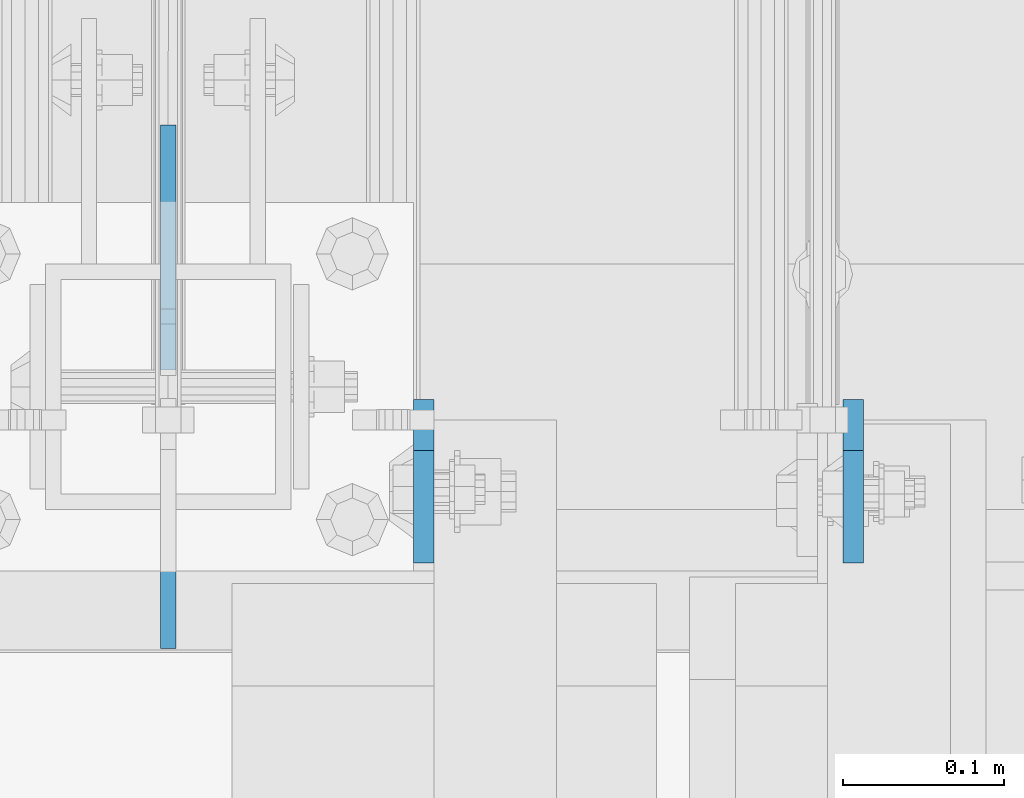
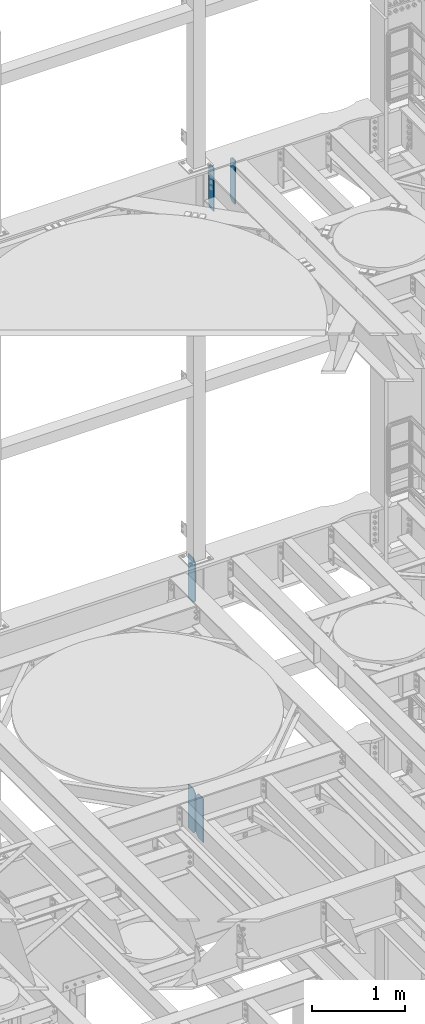
# One storey, part 1801 of 1876: 5 plates, 3 elements without a shape of their own.
"""IFC2X3 building model written with IfcOpenShell, lengths in millimetres."""

import ifcopenshell
import ifcopenshell.guid

model = None  # the IFC model being written
_history = None  # IfcOwnerHistory: only IFC2X3 demands one
_inside = {}  # id of a spatial element -> (the spatial element, [elements in it])
_under = {}  # id of a project, library or spatial element -> (it, [spatial elements below it])
_declared = {}  # id of a project -> (the project, [libraries it declares])
_typed = {}  # id of a type object -> (the type object, [elements of that type])
_made_of = {}  # id of a material, layer set ... -> (it, [elements and type objects made of it])


def new_model(schema):
    """Start an empty IFC model of exactly this schema.

    Asked for "IFC4X3", IfcOpenShell would pick the latest addendum, in which some entities
    have other attributes; the version numbers below select the first issue.
    IFC2X3 requires an IfcOwnerHistory on every rooted entity: one is made here for all.
    """
    global model, _history
    if schema == "IFC4X3":
        model = ifcopenshell.file(schema_version=(4, 3, 0, 0))
    else:
        model = ifcopenshell.file(schema=schema)
    _inside.clear()
    _under.clear()
    _declared.clear()
    _typed.clear()
    _made_of.clear()
    _history = None
    if model.schema == "IFC2X3":
        org = make("IfcOrganization", Name="unknown")
        user = make(
            "IfcPersonAndOrganization",
            ThePerson=make("IfcPerson", FamilyName="unknown"),
            TheOrganization=org,
        )
        app = make(
            "IfcApplication",
            ApplicationDeveloper=org,
            Version="unknown",
            ApplicationFullName="unknown",
            ApplicationIdentifier="unknown",
        )
        _history = make(
            "IfcOwnerHistory",
            OwningUser=user,
            OwningApplication=app,
            ChangeAction="ADDED",
            CreationDate=0,
        )
    return model


def make(cls, **values):
    """One entity of the class cls with the attributes given. An attribute that is None is left unset."""
    return model.create_entity(
        cls, **{name: value for name, value in values.items() if value is not None}
    )


def rooted(cls, **values):
    """An entity with a GlobalId (a new one), such as an element, a storey or a relation."""
    return make(cls, GlobalId=ifcopenshell.guid.new(), OwnerHistory=_history, **values)


def si_unit(unit_type, name, prefix=None):
    """IfcSIUnit, for example si_unit("LENGTHUNIT", "METRE", prefix="MILLI")."""
    return make("IfcSIUnit", UnitType=unit_type, Prefix=prefix, Name=name)


def assignment(units):
    """IfcUnitAssignment: the units of a project."""
    return None if units is None else make("IfcUnitAssignment", Units=units)


def point(xyz):
    """IfcCartesianPoint."""
    return None if xyz is None else make("IfcCartesianPoint", Coordinates=xyz)


def direction(xyz):
    """IfcDirection."""
    return None if xyz is None else make("IfcDirection", DirectionRatios=xyz)


def frame(location, z_axis=None, x_axis=None):
    """IfcAxis2Placement3D, a coordinate frame: its origin and axes. An axis left out is left unset."""
    return make(
        "IfcAxis2Placement3D",
        Location=point(location),
        Axis=direction(z_axis),
        RefDirection=direction(x_axis),
    )


def origin_with_axes():
    """The frame at (0, 0, 0) with the z axis (0, 0, 1) and the x axis (1, 0, 0) written out."""
    return frame((0.0, 0.0, 0.0), z_axis=(0.0, 0.0, 1.0), x_axis=(1.0, 0.0, 0.0))


def place(relative_to, where):
    """IfcLocalPlacement: puts the frame where relative to a parent placement (None: the world)."""
    return make(
        "IfcLocalPlacement", PlacementRelTo=relative_to, RelativePlacement=where
    )


def context(
    kind, dimensions, precision=None, world=None, true_north=None, identifier=None
):
    """IfcGeometricRepresentationContext, for example the 3D "Model" context."""
    return make(
        "IfcGeometricRepresentationContext",
        ContextIdentifier=identifier,
        ContextType=kind,
        CoordinateSpaceDimension=dimensions,
        Precision=precision,
        WorldCoordinateSystem=world,
        TrueNorth=true_north,
    )


def subcontext(parent, identifier, kind, view, scale=None):
    """IfcGeometricRepresentationSubContext, for example "Body" below "Model"."""
    return make(
        "IfcGeometricRepresentationSubContext",
        ContextIdentifier=identifier,
        ContextType=kind,
        ParentContext=parent,
        TargetScale=scale,
        TargetView=view,
    )


def project(units=None, contexts=None):
    """IfcProject with its units and contexts."""
    return rooted(
        "IfcProject",
        Name="project",
        RepresentationContexts=contexts,
        UnitsInContext=assignment(units),
    )


def spatial(cls, under=None, at=None, **own):
    """A site, building, storey or space (cls), placed at a placement, below another one or the project."""
    s = rooted(cls, ObjectPlacement=at, **own)
    if under is not None:
        _under.setdefault(under.id(), (under, []))[1].append(s)
    return s


def faces_of(points, faces, orient=None, outer=None):
    """IfcFace entities. A face is a list of loops; a loop is a list of indices into points, from 0.

    orient and outer hold one flag for each loop. By default every Orientation is true, the
    first loop of a face is its IfcFaceOuterBound and the others are IfcFaceBound.
    """
    made = []
    for i, loops in enumerate(faces):
        bounds = []
        for j, loop in enumerate(loops):
            is_outer = j == 0 if outer is None else outer[i][j]
            bounds.append(
                make(
                    "IfcFaceOuterBound" if is_outer else "IfcFaceBound",
                    Bound=make("IfcPolyLoop", Polygon=[points[k] for k in loop]),
                    Orientation=True if orient is None else orient[i][j],
                )
            )
        made.append(make("IfcFace", Bounds=bounds))
    return made


def faceted_brep(points, faces, orient=None, outer=None, voids=None):
    """IfcFacetedBrep: a solid bounded by flat faces; with voids (closed shells), ...WithVoids."""
    shared = [point(p) for p in points]
    hull = make("IfcClosedShell", CfsFaces=faces_of(shared, faces, orient, outer))
    if voids is None:
        return make("IfcFacetedBrep", Outer=hull)
    return make(
        "IfcFacetedBrepWithVoids",
        Outer=hull,
        Voids=[
            make(cls, CfsFaces=faces_of(shared, fs, o, b)) for cls, fs, o, b in voids
        ],
    )


def shape(context_of_items, identifier, shape_type, items):
    """IfcShapeRepresentation: the items that make up one representation, for example the "Body"."""
    return make(
        "IfcShapeRepresentation",
        ContextOfItems=context_of_items,
        RepresentationIdentifier=identifier,
        RepresentationType=shape_type,
        Items=items,
    )


def material(Name=None, Category=None):
    """IfcMaterial."""
    return make("IfcMaterial", Name=Name, Category=Category)


def made_of(thing, what):
    """Note that an element or type object is made of a material, layer set ...; save() writes the relation."""
    if what is not None:
        _made_of.setdefault(what.id(), (what, []))[1].append(thing)
    return thing


def type_object(cls, material=None, **own):
    """A type object (cls), such as IfcWallType, which elements share."""
    return made_of(rooted(cls, **own), material)


def element(
    cls,
    number,
    at=None,
    inside=None,
    cuts=None,
    type_object=None,
    material=None,
    context=None,
    identifier="Body",
    shape_type=None,
    held_by="IfcProductDefinitionShape",
    body=None,
    shapes=None,
    **own,
):
    """One element of the class cls, such as IfcWall. Its Tag is "e" and its number.

    at: its placement. inside: the storey or other place that contains it. cuts: it is an
    opening in that element (IfcRelVoidsElement). A single representation is given by context,
    identifier, shape_type and body (its items); several are given by shapes. held_by: the class
    of the entity that holds the representations. save() writes the other relations.
    """
    e = rooted(cls, Tag="e%d" % number, ObjectPlacement=at, **own)
    if body is not None:
        shapes = [shape(context, identifier, shape_type, body)]
    if shapes is not None:
        e.Representation = make(held_by, Representations=shapes)
    if inside is not None:
        _inside.setdefault(inside.id(), (inside, []))[1].append(e)
    if cuts is not None:
        rooted(
            "IfcRelVoidsElement", RelatingBuildingElement=cuts, RelatedOpeningElement=e
        )
    if type_object is not None:
        _typed.setdefault(type_object.id(), (type_object, []))[1].append(e)
    return made_of(e, material)


def aggregate(whole, parts):
    """IfcRelAggregates: a whole, such as a stair, and the parts it consists of."""
    return rooted("IfcRelAggregates", RelatingObject=whole, RelatedObjects=parts)


def save(model, path):
    """Write the relations noted so far, then the file.

    IfcRelAggregates (storeys below a building ...), IfcRelContainedInSpatialStructure (elements
    in a storey), IfcRelDefinesByType, IfcRelAssociatesMaterial and IfcRelDeclares: one each for
    every whole, place, type object, material and project.
    """
    for whole, parts in _under.values():
        aggregate(whole, parts)
    for where, things in _inside.values():
        rooted(
            "IfcRelContainedInSpatialStructure",
            RelatedElements=things,
            RelatingStructure=where,
        )
    for kind, things in _typed.values():
        rooted("IfcRelDefinesByType", RelatedObjects=things, RelatingType=kind)
    for what, things in _made_of.values():
        rooted("IfcRelAssociatesMaterial", RelatedObjects=things, RelatingMaterial=what)
    for by, libraries in _declared.values():
        rooted("IfcRelDeclares", RelatingContext=by, RelatedDefinitions=libraries)
    model.write(path)


model = new_model("IFC2X3")

# Units and contexts
model_context = context("Model", 3, precision=1e-05, world=origin_with_axes())
body_context = subcontext(model_context, "Body", "Model", "MODEL_VIEW")
ifc_project = project(units=[si_unit("LENGTHUNIT", "METRE", prefix="MILLI"), si_unit("AREAUNIT", "SQUARE_METRE"), si_unit("VOLUMEUNIT", "CUBIC_METRE"), si_unit("MASSUNIT", "GRAM", prefix="KILO"), si_unit("TIMEUNIT", "SECOND"), si_unit("PLANEANGLEUNIT", "RADIAN"), si_unit("SOLIDANGLEUNIT", "STERADIAN"), si_unit("THERMODYNAMICTEMPERATUREUNIT", "DEGREE_CELSIUS"), si_unit("LUMINOUSINTENSITYUNIT", "LUMEN")], contexts=[model_context])

# Site, building, storey
site_placement = place(None, origin_with_axes())
site = spatial("IfcSite", under=ifc_project, at=site_placement, CompositionType="ELEMENT")
building_placement = place(site_placement, origin_with_axes())
building = spatial("IfcBuilding", under=site, at=building_placement, Name="Undefined", CompositionType="ELEMENT")
storey_placement = place(building_placement, origin_with_axes())
storey = spatial("IfcBuildingStorey", under=building, at=storey_placement, Name="Undefined", CompositionType="ELEMENT", Elevation=0.0)

# Assembly, plates
assembly_1_placement = place(storey_placement, origin_with_axes())
assembly_1 = element("IfcElementAssembly", 1, at=assembly_1_placement, inside=storey, Name="BEAM", AssemblyPlace="NOTDEFINED", PredefinedType="RIGID_FRAME")
ifc_material = material(Name="STEEL/A36")
plate_type_1 = type_object("IfcPlateType", PredefinedType="NOTDEFINED")
plate_1_placement = place(assembly_1_placement, frame((5505.44999990463, 13708.0625, 12709.525), z_axis=(0.0, 0.0, 1.0), x_axis=(0.0, -1.0, 0.0)))
plate_1 = element("IfcPlate", 2, at=plate_1_placement, type_object=plate_type_1, material=ifc_material, Name="PLATE", context=body_context, shape_type="Brep", body=[
    faceted_brep([(0.0, -6.34999999999991, 31.75), (0.0, -6.35000000000036, 541.337524414062), (0.0, 6.35000000000036, 541.337524414062), (0.0, 6.34999999999991, 31.75), (31.75, -6.35000000000036, 573.087524414062), (31.75, 6.35000000000036, 573.087524414062), (101.599998474121, -6.35000000000036, 573.087524414062), (101.599998474121, 6.35000000000036, 573.087524414062), (101.599998474121, -6.35000000000036, 0.0), (101.599998474121, 6.35000000000036, 0.0), (31.75, -6.34999999999991, 0.0), (31.75, 6.34999999999991, 0.0)], [[[0, 1, 2, 3]], [[1, 4, 5, 2]], [[4, 6, 7, 5]], [[6, 8, 9, 7]], [[8, 10, 11, 9]], [[10, 0, 3, 11]], [[5, 7, 9, 11, 3, 2]], [[10, 8, 6, 4, 1, 0]]]),
])
plate_2_placement = place(assembly_1_placement, frame((5238.74999834896, 13708.0625, 12709.525), z_axis=(0.0, 0.0, 1.0), x_axis=(0.0, -1.0, 0.0)))
plate_2 = element("IfcPlate", 3, at=plate_2_placement, type_object=plate_type_1, material=ifc_material, Name="PLATE", context=body_context, shape_type="Brep", body=[
    faceted_brep([(0.0, -6.34999999999991, 31.75), (0.0, -6.35000000000036, 541.337524414062), (0.0, 6.35000000000036, 541.337524414062), (0.0, 6.34999999999991, 31.75), (31.75, -6.35000000000036, 573.087524414062), (31.75, 6.35000000000036, 573.087524414062), (101.599998474121, -6.35000000000036, 573.087524414062), (101.599998474121, 6.35000000000036, 573.087524414062), (101.599998474121, -6.35000000000036, 0.0), (101.599998474121, 6.35000000000036, 0.0), (31.75, -6.34999999999991, 0.0), (31.75, 6.34999999999991, 0.0)], [[[0, 1, 2, 3]], [[1, 4, 5, 2]], [[4, 6, 7, 5]], [[6, 8, 9, 7]], [[8, 10, 11, 9]], [[10, 0, 3, 11]], [[5, 7, 9, 11, 3, 2]], [[10, 8, 6, 4, 1, 0]]]),
])
aggregate(assembly_1, [plate_1, plate_2])

# Assembly, plate
assembly_2_placement = place(storey_placement, origin_with_axes())
assembly_2 = element("IfcElementAssembly", 4, at=assembly_2_placement, inside=storey, Name="BEAM", AssemblyPlace="NOTDEFINED", PredefinedType="RIGID_FRAME")
plate_type_2 = type_object("IfcPlateType", PredefinedType="NOTDEFINED")
plate_3_placement = place(assembly_2_placement, frame((5080.0, 13726.31875, 7542.2125), z_axis=(0.0, 0.0, 1.0), x_axis=(0.0, 1.0, 0.0)))
plate_3 = element("IfcPlate", 5, at=plate_3_placement, type_object=plate_type_2, material=ifc_material, Name="PLATE", context=body_context, shape_type="Brep", body=[
    faceted_brep([(0.0, -4.76249999999982, 38.0999984741211), (0.0, -4.76249999999982, 536.574989318848), (0.0, 4.76249999999982, 536.574989318848), (0.0, 4.76249999999982, 38.0999984741211), (38.0999984741211, -4.76249999999982, 574.674987792969), (38.0999984741211, 4.76249999999982, 574.674987792969), (152.39999389651, -4.76250000000255, 574.674987792969), (152.39999389651, 4.76249999999891, 574.674987792969), (152.399993896484, -4.76249999999982, 0.0), (152.399993896484, 4.76249999999982, 0.0), (38.0999984741211, -4.76249999999982, 0.0), (38.0999984741211, 4.76249999999982, 0.0)], [[[0, 1, 2, 3]], [[1, 4, 5, 2]], [[4, 6, 7, 5]], [[6, 8, 9, 7]], [[8, 10, 11, 9]], [[10, 0, 3, 11]], [[5, 7, 9, 11, 3, 2]], [[10, 8, 6, 4, 1, 0]]]),
])
aggregate(assembly_2, [plate_3])

# Assembly, plates
assembly_3_placement = place(storey_placement, origin_with_axes())
assembly_3 = element("IfcElementAssembly", 6, at=assembly_3_placement, inside=storey, Name="BEAM", AssemblyPlace="NOTDEFINED", PredefinedType="RIGID_FRAME")
plate_4_placement = place(assembly_3_placement, frame((5080.0, 13553.28125, 4519.6125), z_axis=(0.0, 0.0, 1.0), x_axis=(0.0, 1.0, 0.0)))
plate_4 = element("IfcPlate", 7, at=plate_4_placement, type_object=plate_type_2, material=ifc_material, Name="PLATE", context=body_context, shape_type="Brep", body=[
    faceted_brep([(0.0, -4.76249999999982, 0.0), (0.0, -4.76249999999982, 574.674987792969), (0.0, 4.76249999999982, 574.674987792969), (0.0, 4.76249999999982, 0.0), (114.299995422363, -4.76249999999982, 574.674987792969), (114.299995422363, 4.76249999999982, 574.674987792969), (152.399993896484, -4.76249999999982, 536.574989318848), (152.399993896484, 4.76249999999982, 536.574989318848), (152.399993896484, -4.76249999999982, 38.0999984741211), (152.399993896484, 4.76249999999982, 38.0999984741211), (114.300003051758, -4.76249999999999, 0.0), (114.300003051758, 4.76249999999999, 0.0)], [[[0, 1, 2, 3]], [[1, 4, 5, 2]], [[4, 6, 7, 5]], [[6, 8, 9, 7]], [[8, 10, 11, 9]], [[10, 0, 3, 11]], [[5, 7, 9, 11, 3, 2]], [[10, 8, 6, 4, 1, 0]]]),
])
plate_5_placement = place(assembly_3_placement, frame((5080.0, 13726.31875, 4519.6125), z_axis=(0.0, 0.0, 1.0), x_axis=(0.0, 1.0, 0.0)))
plate_5 = element("IfcPlate", 8, at=plate_5_placement, type_object=plate_type_2, material=ifc_material, Name="PLATE", context=body_context, shape_type="Brep", body=[
    faceted_brep([(0.0, -4.76249999999982, 38.0999984741211), (0.0, -4.76249999999982, 536.574989318848), (0.0, 4.76249999999982, 536.574989318848), (0.0, 4.76249999999982, 38.0999984741211), (38.0999984741211, -4.76249999999982, 574.674987792969), (38.0999984741211, 4.76249999999982, 574.674987792969), (152.39999389651, -4.76250000000255, 574.674987792969), (152.39999389651, 4.76249999999891, 574.674987792969), (152.399993896484, -4.76249999999982, 0.0), (152.399993896484, 4.76249999999982, 0.0), (38.0999984741211, -4.76249999999982, 0.0), (38.0999984741211, 4.76249999999982, 0.0)], [[[0, 1, 2, 3]], [[1, 4, 5, 2]], [[4, 6, 7, 5]], [[6, 8, 9, 7]], [[8, 10, 11, 9]], [[10, 0, 3, 11]], [[5, 7, 9, 11, 3, 2]], [[10, 8, 6, 4, 1, 0]]]),
])
aggregate(assembly_3, [plate_4, plate_5])

save(model, "model.ifc")
